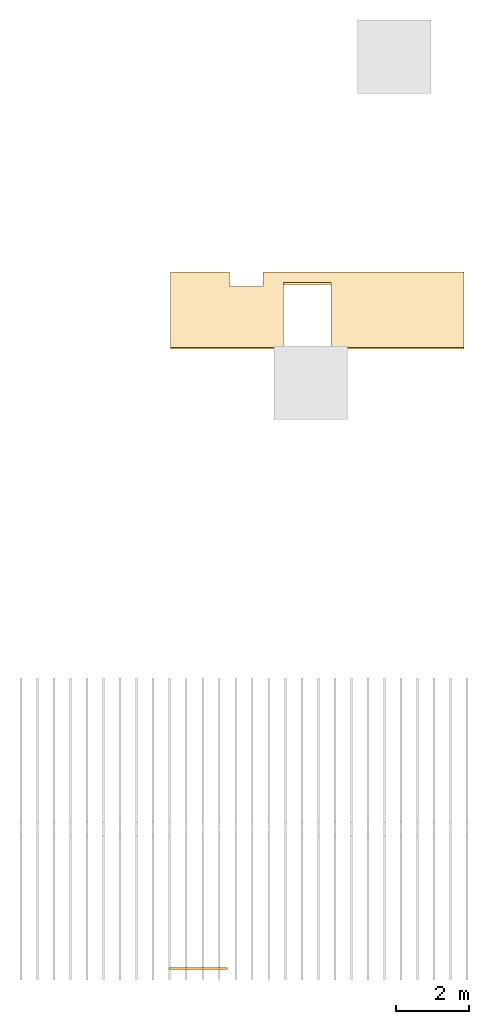
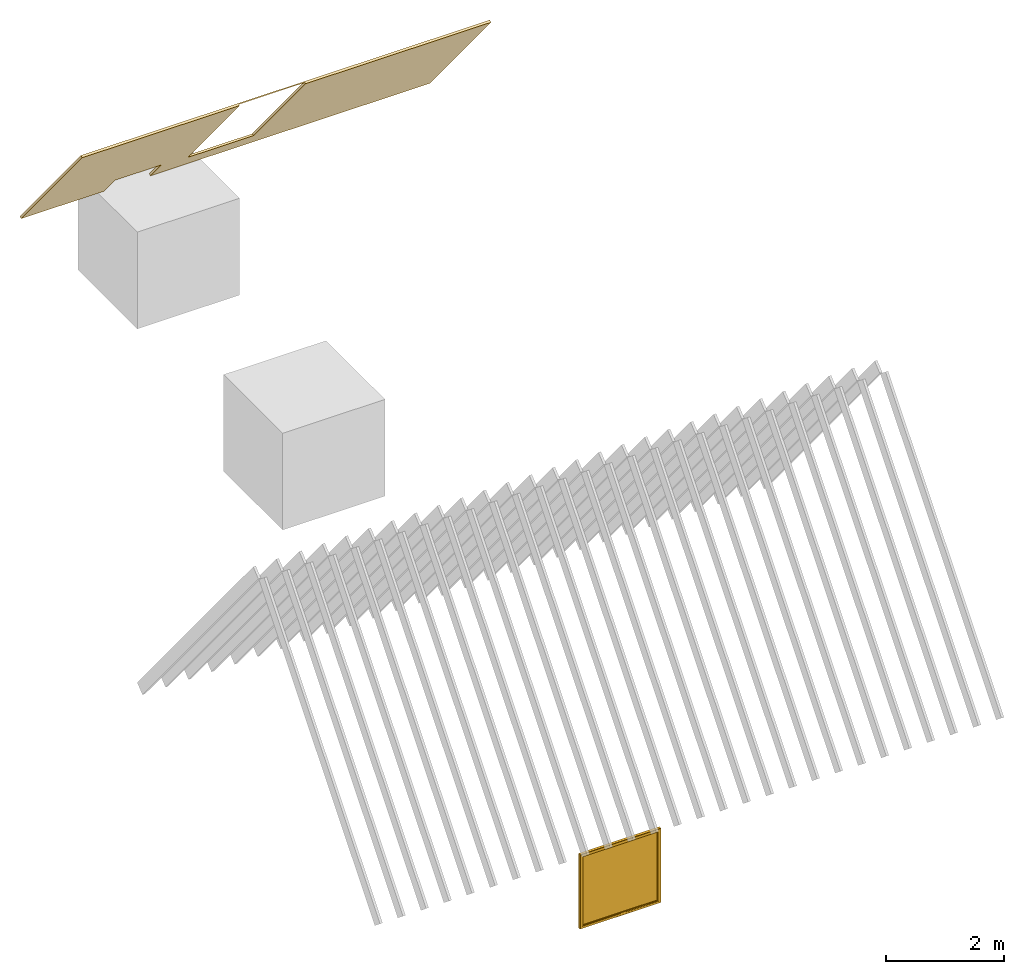
# Not in any storey, part 3 of 4: 1 covering, 1 window.
"""IFC4 model written with IfcOpenShell, lengths in metres."""

from ifc_helpers import new_model, entity, si_unit, converted_unit, frame, frame_2d, origin_with_axes, place, context, project, polygons, shape, element, save


model = new_model("IFC4")

# Units and contexts
model_context = context("Model", 3, precision=1e-05, world=origin_with_axes())
plan_context = context("Plan", 2, precision=1e-05, world=frame_2d((0.0, 0.0, 0.0), x_axis=(1.0, 0.0, 0.0)))
ifc_project = project(units=[si_unit("AREAUNIT", "SQUARE_METRE"), si_unit("VOLUMEUNIT", "CUBIC_METRE"), si_unit("LENGTHUNIT", "METRE"), converted_unit("PLANEANGLEUNIT", "degree", entity("IfcReal", 0.0174532925199433), si_unit("PLANEANGLEUNIT", "RADIAN"), dimensions=[0, 0, 0, 0, 0, 0, 0])], contexts=[model_context, plan_context])

# Window
window_placement = place(None, frame((-2.33564019203186, -15.9859809875488, 0.0529392957687378), z_axis=(0.0, 0.0, 1.0), x_axis=(-1.0, -3.89414367418794e-07, 0.0)))
element("IfcWindow", 1, at=window_placement, Name="Window Office", PredefinedType="WINDOW", shapes=[
    shape(model_context, None, "Tessellation", [polygons([(-0.0770422890782356, -0.0599999725818634, 0.776858150959015), (1.4979293346405, -0.0600002259016037, 0.776858150959015), (-0.0810422897338867, -0.0559999719262123, 0.772858142852783), (1.50192928314209, -0.0560002252459526, 0.772858142852783), (1.44192934036255, -0.0350002273917198, 2.25039982795715), (1.44192934036255, -0.0560002252459526, 2.25039982795715), (-0.0210422910749912, -0.0559999719262123, 2.25039982795715), (-0.0210422910749912, -0.0349999740719795, 2.25039982795715), (-0.0210422910749912, -0.0249999724328518, 2.25039982795715), (-0.0210422910749912, -0.0249999724328518, 0.832858145236969), (-0.0210422910749912, -0.00399997364729643, 0.832858145236969), (-0.0210422910749912, -0.00399997364729643, 2.25039982795715), (-0.0210422910749912, -0.0559999719262123, 0.832858145236969), (-0.0360422916710377, -0.0559999719262123, 2.26539969444275), (-0.0360422916710377, -0.0559999719262123, 0.817858159542084), (-0.0810422897338867, -0.0299999732524157, 0.772858142852783), (-0.0810422897338867, -0.00399997364729643, 0.772858142852783), (1.50192928314209, -0.00400022836402059, 0.772858142852783), (1.50192928314209, -0.0300002284348011, 0.772858142852783), (-0.0360422916710377, -0.0599999725818634, 2.26539969444275), (-0.0360422916710377, -0.0599999725818634, 0.817858159542084), (-0.0770422890782356, -0.0599999725818634, 2.30639982223511), (-0.0770422890782356, 2.64069299760195e-08, 2.30639982223511), (1.4979293346405, -2.27959802145961e-07, 2.30639982223511), (-0.0810422897338867, -0.00399997364729643, 2.31039977073669), (1.50192928314209, -0.00400022836402059, 2.31039977073669), (1.45692932605743, -0.0560002252459526, 2.26539969444275), (1.45692932605743, -0.0600002259016037, 2.26539969444275), (1.50192928314209, -0.0300002284348011, 2.31039977073669), (1.50192928314209, -0.0560002252459526, 2.31039977073669), (1.4979293346405, -0.0600002259016037, 2.30639982223511), (1.4979293346405, -2.27959802145961e-07, 0.776858150959015), (1.44192934036255, -0.0350002273917198, 0.832858145236969), (1.44192934036255, -0.0560002252459526, 0.832858145236969), (1.45692932605743, -0.0560002252459526, 0.817858159542084), (1.45692932605743, -0.0600002259016037, 0.817858159542084), (-0.0360422916710377, 2.64069299760195e-08, 2.26539969444275), (-0.0360422916710377, -0.00399997364729643, 2.26539969444275), (-0.0360422916710377, -0.00399997364729643, 0.817858159542084), (-0.0360422916710377, 2.64069299760195e-08, 0.817858159542084), (-0.0770422890782356, 2.64069299760195e-08, 0.776858150959015), (1.44192934036255, -0.00400022836402059, 0.832858145236969), (1.44192934036255, -0.0250002276152372, 0.832858145236969), (1.44192934036255, -0.0250002276152372, 2.25039982795715), (1.44192934036255, -0.00400022836402059, 2.25039982795715), (-0.0210422910749912, -0.0349999740719795, 0.832858145236969), (-0.0810422897338867, -0.0559999719262123, 2.31039977073669), (-0.0810422897338867, -0.0299999732524157, 2.31039977073669), (1.45692932605743, -2.27959802145961e-07, 2.26539969444275), (1.45692932605743, -0.00400022836402059, 2.26539969444275), (1.45692932605743, -0.00400022836402059, 0.817858159542084), (1.45692932605743, -2.27959802145961e-07, 0.817858159542084)], [[[17, 41, 32, 18]], [[9, 44, 43, 10]], [[25, 17, 16, 48]], [[13, 7, 14]], [[15, 13, 14]], [[14, 27, 28, 20]], [[1, 21, 20]], [[1, 20, 22]], [[11, 10, 43, 42]], [[11, 12, 9, 10]], [[27, 7, 6]], [[27, 14, 7]], [[47, 30, 29, 48]], [[22, 28, 31]], [[20, 28, 22]], [[30, 31, 2, 4]], [[35, 36, 28, 27]], [[18, 26, 29, 19]], [[35, 27, 6]], [[35, 6, 34]], [[5, 33, 34, 6]], [[2, 31, 28]], [[36, 2, 28]], [[31, 30, 47, 22]], [[19, 4, 3, 16]], [[37, 49, 50, 38]], [[13, 35, 34]], [[15, 35, 13]], [[9, 10, 46, 8]], [[1, 36, 21]], [[2, 36, 1]], [[19, 29, 30, 4]], [[25, 23, 41, 17]], [[37, 40, 41]], [[23, 37, 41]], [[10, 43, 33, 46]], [[38, 11, 39]], [[12, 11, 38]], [[18, 19, 16, 17]], [[7, 8, 5, 6]], [[44, 9, 8, 5]], [[49, 37, 23]], [[49, 23, 24]], [[39, 51, 52, 40]], [[50, 45, 12]], [[50, 12, 38]], [[44, 45, 42, 43]], [[3, 1, 22, 47]], [[45, 44, 9, 12]], [[1, 3, 4, 2]], [[24, 32, 52]], [[24, 52, 49]], [[46, 8, 5, 33]], [[50, 51, 42]], [[50, 42, 45]], [[48, 16, 3, 47]], [[46, 8, 7, 13]], [[40, 37, 38, 39]], [[23, 25, 26, 24]], [[52, 41, 40]], [[32, 41, 52]], [[43, 44, 5, 33]], [[51, 39, 11]], [[51, 11, 42]], [[46, 13, 34, 33]], [[15, 14, 20, 21]], [[18, 32, 24, 26]], [[48, 29, 26, 25]], [[21, 36, 35, 15]], [[49, 52, 51, 50]]])]),
])

# Covering
covering_placement = place(None, frame((2.94633889198303, 1.98802328109741, 5.25050783157349), z_axis=(2.88761242472901e-07, -0.772404372692108, -0.635131061077118), x_axis=(1.0, 2.88761242472901e-07, 1.03475976231948e-07)))
element("IfcCovering", 2, at=covering_placement, Name="Ceiling", PredefinedType="CEILING", shapes=[
    shape(model_context, None, "Tessellation", [polygons([(-6.76313018798828, -1.59362435340881, -0.0222694482654333), (-6.76313018798828, -1.59362435340881, 0.0222678985446692), (-6.76313018798828, 1.66154062747955, -0.0222694482654333), (-6.76313018798828, 1.66154062747955, 0.0222678985446692), (1.23025751113892, -1.59362411499023, -0.0222688149660826), (1.23025751113892, -1.59362411499023, 0.0222685318440199), (1.23025751113892, 1.66154086589813, -0.0222688149660826), (1.23025751113892, 1.66154086589813, 0.0222685318440199), (-3.68647432327271, 1.66154074668884, -0.00102299742866307), (-3.68647432327271, 1.66154074668884, 0.0222681798040867), (-2.39136481285095, 1.66154074668884, 0.0222682971507311), (-2.39136481285095, 1.66154074668884, -0.00102295319084078), (-5.14753866195679, -1.59362435340881, 0.0222680456936359), (-4.23423624038696, -1.59362423419952, 0.0222681295126677), (-4.23423624038696, -1.59362423419952, -0.0222692172974348), (-5.14753866195679, -1.59362435340881, -0.0222693011164665), (-3.68647432327271, 1.64407050609589, -0.0222691670060158), (-2.39136481285095, 1.64407050609589, -0.0222690496593714), (-5.14753866195679, -0.953339636325836, -0.0222693011164665), (-4.23423624038696, -0.953339755535126, -0.0222692172974348), (-3.68647432327271, -1.14009618759155, -0.0222691670060158), (-2.39136481285095, -1.14009606838226, -0.0222690496593714), (-3.36333894729614, -1.14009618759155, -0.0222691372036934), (-4.23423624038696, -1.00750315189362, 0.0222681295126677), (-5.14753866195679, -1.00750303268433, 0.0222680456936359), (-3.68647432327271, -1.10347414016724, 0.0222681798040867), (-2.39136481285095, -1.10347402095795, 0.0222682971507311)], [[[1, 2, 4, 3]], [[11, 8, 7, 3, 4, 10, 9, 12]], [[7, 8, 6, 5]], [[2, 1, 16, 13]], [[5, 6, 14, 15]], [[20, 19, 16, 1, 3, 7, 5, 15, 23, 22, 18, 17, 21]], [[23, 15, 20, 21]], [[26, 10, 4, 2, 13, 25, 24, 14, 6, 8, 11, 27]], [[13, 16, 19, 25]], [[20, 15, 14, 24]], [[19, 20, 24, 25]], [[26, 21, 17, 9, 10]], [[12, 18, 22, 27, 11]], [[18, 12, 9, 17]], [[22, 23, 21, 26, 27]]])]),
])

save(model, "model.ifc")
